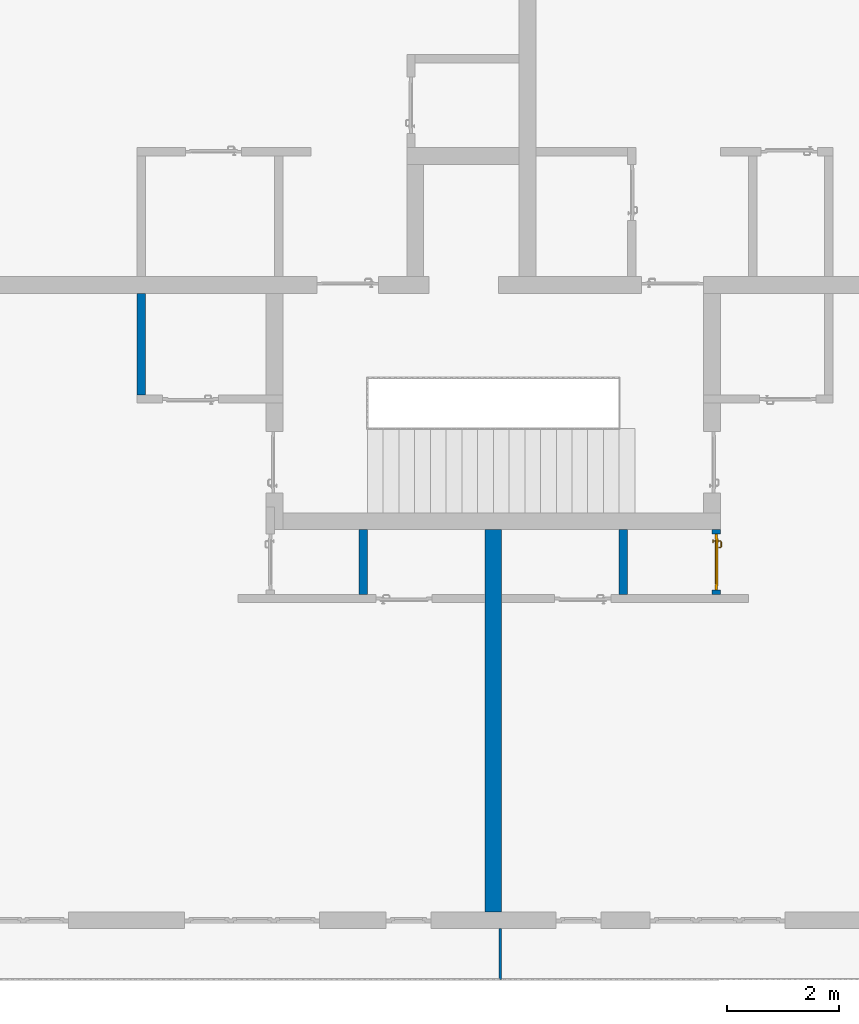
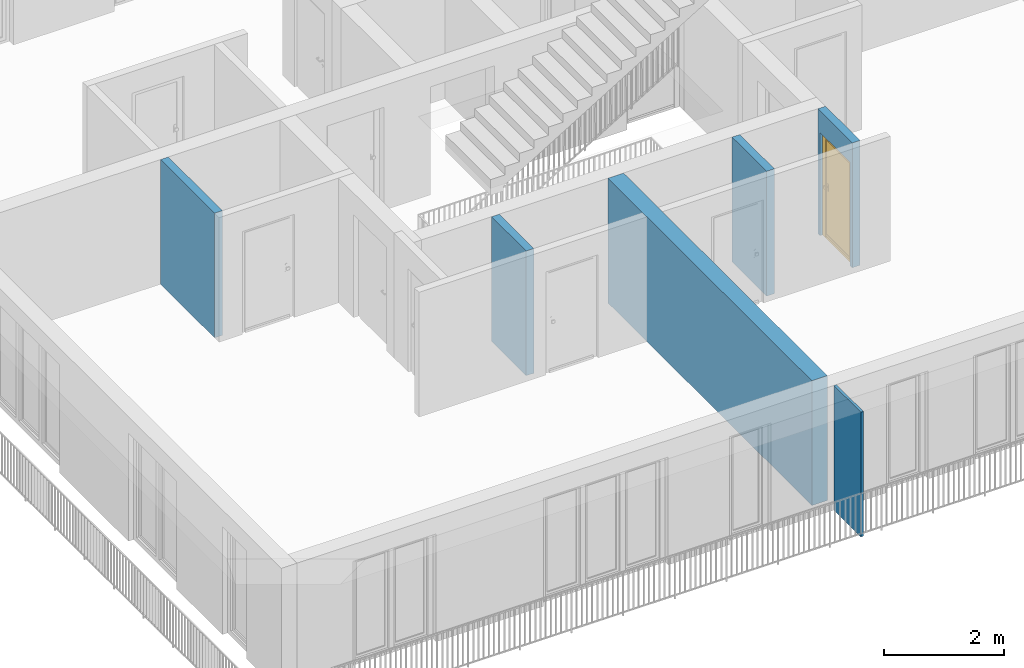
# One storey, part 4 of 48: 6 walls, 1 door, 1 opening.
"""IFC4 building model written with IfcOpenShell, lengths in metres."""

from ifc_helpers import new_model, entity, si_unit, converted_unit, derived_unit, direction, frame, origin_with_axes, place, context, subcontext, project, spatial, polygons, source, transform, mapped, material, type_object, element, fill, save


model = new_model("IFC4")

# Units and contexts
model_context = context("Model", 3, precision=1e-05, world=origin_with_axes(), true_north=direction((0.0, 1.0)))
body_context = subcontext(model_context, "Body", "Model", "MODEL_VIEW")
ifc_project = project(units=[si_unit("LENGTHUNIT", "METRE"), si_unit("AREAUNIT", "SQUARE_METRE"), si_unit("VOLUMEUNIT", "CUBIC_METRE"), converted_unit("PLANEANGLEUNIT", "DEGREE", entity("IfcPlaneAngleMeasure", 0.0174532925199), si_unit("PLANEANGLEUNIT", "RADIAN"), dimensions=[0, 0, 0, 0, 0, 0, 0]), converted_unit("TIMEUNIT", "Year", entity("IfcTimeMeasure", 31556926.0), si_unit("TIMEUNIT", "SECOND"), dimensions=[0, 0, 1, 0, 0, 0, 0]), si_unit("MASSUNIT", "GRAM", prefix="KILO"), si_unit("THERMODYNAMICTEMPERATUREUNIT", "DEGREE_CELSIUS"), si_unit("LUMINOUSINTENSITYUNIT", "LUMEN"), si_unit("ENERGYUNIT", "JOULE", prefix="MEGA"), derived_unit("THERMALCONDUCTANCEUNIT", [(si_unit("POWERUNIT", "WATT"), 1), (si_unit("LENGTHUNIT", "METRE"), -1), (si_unit("THERMODYNAMICTEMPERATUREUNIT", "KELVIN"), -1)]), derived_unit("SPECIFICHEATCAPACITYUNIT", [(si_unit("ENERGYUNIT", "JOULE"), 1), (si_unit("MASSUNIT", "GRAM", prefix="KILO"), -1), (si_unit("THERMODYNAMICTEMPERATUREUNIT", "KELVIN"), -1)]), derived_unit("MASSDENSITYUNIT", [(si_unit("MASSUNIT", "GRAM", prefix="KILO"), 1), (si_unit("VOLUMEUNIT", "CUBIC_METRE"), -1)])], contexts=[model_context])

# Site, building, storey
site_placement = place(None, origin_with_axes())
site = spatial("IfcSite", under=ifc_project, at=site_placement, CompositionType="ELEMENT")
building_placement = place(site_placement, origin_with_axes())
building = spatial("IfcBuilding", under=site, at=building_placement, CompositionType="ELEMENT")
storey_placement = place(building_placement, frame((0.0, 0.0, 3.4), z_axis=(0.0, 0.0, 1.0), x_axis=(1.0, 0.0, 0.0)))
storey = spatial("IfcBuildingStorey", under=building, at=storey_placement, Name="1. Geschoss", CompositionType="ELEMENT", Elevation=3.4)

# Wall
ifc_material_1 = material()
wall_type_1 = type_object("IfcWallType", Name="300", PredefinedType="NOTDEFINED")
wall_1_placement = place(storey_placement, frame((-1.2021993804, -2.52881223104, 0.0), z_axis=(0.0, 0.0, 1.0), x_axis=(0.0, -1.0, 0.0)))
element("IfcWall", 1, at=wall_1_placement, inside=storey, type_object=wall_type_1, material=ifc_material_1, Name="Wand-001", PredefinedType="NOTDEFINED", context=body_context, shape_type="Tessellation", body=[
    polygons([(0.3, -0.15, 0.0), (0.3, -0.15, 2.54), (0.3, 0.15, 2.54), (0.3, 0.15, 0.0), (7.1, -0.15, 0.0), (7.1, -0.15, 2.54), (7.1, 0.15, 2.54), (7.1, 0.15, 0.0)], [[[1, 2, 3, 4]], [[5, 6, 2, 1]], [[6, 7, 3, 2]], [[4, 3, 7, 8]], [[1, 4, 8, 5]], [[8, 7, 6, 5]]], closed=True),
])

# Wall, opening, door
wall_type_2 = type_object("IfcWallType", Name="150", PredefinedType="NOTDEFINED")
wall_2_placement = place(storey_placement, frame((2.8378006196, -4.12881223104, 0.0), z_axis=(0.0, 0.0, 1.0), x_axis=(0.0, 1.0, 0.0)))
wall_2 = element("IfcWall", 2, at=wall_2_placement, inside=storey, type_object=wall_type_2, material=ifc_material_1, Name="Wand-002", PredefinedType="NOTDEFINED", context=body_context, shape_type="Tessellation", body=[
    polygons([(0.225, 0.0, 0.0), (0.225, 0.0, 2.1), (1.225, 0.0, 2.1), (1.225, 0.0, 0.0), (1.3, 0.0, 0.0), (1.3, 0.0, 2.54), (0.15, 0.0, 2.54), (0.15, 0.0, 0.0), (0.225, 0.1, 0.0), (0.225, 0.15, 0.0), (0.225, 0.15, 2.1), (1.225, 0.15, 2.1), (1.225, 0.1, 0.0), (1.225, 0.15, 0.0), (1.3, 0.15, 0.0), (1.3, 0.15, 2.54), (0.15, 0.15, 2.54), (0.15, 0.15, 0.0)], [[[1, 2, 3, 4, 5, 6, 7, 8]], [[2, 1, 9, 10, 11]], [[3, 2, 11, 12]], [[13, 4, 3, 12, 14]], [[4, 13, 14, 15, 5]], [[6, 5, 15, 16]], [[6, 16, 17, 7]], [[17, 18, 8, 7]], [[9, 1, 8, 18, 10]], [[15, 14, 12, 11, 10, 18, 17, 16]]], closed=True),
])
opening_placement = place(wall_2_placement, frame((0.725, 0.0, 0.0), z_axis=(0.0, 0.0, 1.0), x_axis=(1.0, 0.0, 0.0)))
opening = element("IfcOpeningElement", 3, at=opening_placement, cuts=wall_2, context=body_context, identifier="Reference", shape_type="Tessellation", body=[
    polygons([(-0.5, 0.1, 0.0), (-0.5, 0.1, 2.1), (-0.5, 0.151, 2.1), (-0.5, 0.151, 0.0), (-0.5, -0.001, 0.0), (-0.5, -0.001, 2.1), (0.5, 0.1, 2.1), (0.5, 0.151, 2.1), (0.5, -0.001, 2.1), (0.5, 0.151, 0.0), (0.5, 0.1, 0.0), (0.5, -0.001, 0.0)], [[[1, 2, 3, 4]], [[2, 1, 5, 6]], [[7, 8, 3, 2, 6, 9]], [[8, 10, 4, 3]], [[1, 4, 10, 11, 12, 5]], [[6, 5, 12, 9]], [[7, 11, 10, 8]], [[11, 7, 9, 12]]], closed=True),
])
door_type = type_object("IfcDoorType", Name="Eingang 01 1-Fl 26", OperationType="SINGLE_SWING_RIGHT", PredefinedType="DOOR")
shared_shape = source(origin_with_axes(), body_context, "Body", "Tessellation", [
    polygons([(0.5, -0.05, 0.0), (0.5, -0.03, 0.0), (0.5, -0.03, 2.1), (0.5, -0.05, 2.1), (0.4, -0.05, 0.0), (0.4, -0.03, 0.0), (0.4, -0.03, 2.0), (0.1301, -0.03, 2.0), (0.0001, -0.03, 2.0), (-0.4, -0.03, 2.0), (-0.4, -0.03, 0.0), (-0.5, -0.03, 0.0), (-0.5, -0.03, 2.1), (-0.5, -0.05, 2.1), (-0.5, -0.05, 0.0), (-0.4, -0.05, 0.0), (-0.4, -0.05, 2.0), (0.0001, -0.05, 2.0), (0.1301, -0.05, 2.0), (0.4, -0.05, 2.0)], [[[1, 2, 3, 4]], [[5, 6, 2, 1]], [[2, 6, 7, 8, 9, 10, 11, 12, 13, 3]], [[4, 3, 13, 14]], [[1, 4, 14, 15, 16, 17, 18, 19, 20, 5]], [[20, 7, 6, 5]], [[19, 8, 7, 20]], [[18, 9, 8, 19]], [[17, 10, 9, 18]], [[16, 11, 10, 17]], [[15, 12, 11, 16]], [[14, 13, 12, 15]]], closed=True),
    polygons([(0.5, -0.03, 0.0), (0.5, 0.0, 0.0), (0.5, 0.0, 2.1), (0.5, -0.03, 2.1), (0.43, -0.03, 0.0), (0.43, 0.0, 0.0), (0.43, 0.0, 2.03), (0.1001, 0.0, 2.03), (0.0301, 0.0, 2.03), (-0.43, 0.0, 2.03), (-0.43, 0.0, 0.0), (-0.5, 0.0, 0.0), (-0.5, 0.0, 2.1), (-0.5, -0.03, 2.1), (-0.5, -0.03, 0.0), (-0.43, -0.03, 0.0), (-0.43, -0.03, 2.03), (0.0301, -0.03, 2.03), (0.1001, -0.03, 2.03), (0.43, -0.03, 2.03)], [[[1, 2, 3, 4]], [[5, 6, 2, 1]], [[2, 6, 7, 8, 9, 10, 11, 12, 13, 3]], [[4, 3, 13, 14]], [[1, 4, 14, 15, 16, 17, 18, 19, 20, 5]], [[20, 7, 6, 5]], [[19, 8, 7, 20]], [[18, 9, 8, 19]], [[17, 10, 9, 18]], [[16, 11, 10, 17]], [[15, 12, 11, 16]], [[14, 13, 12, 15]]], closed=True),
    polygons([(0.43, 0.01, 0.0), (-0.43, 0.01, 0.0), (-0.43, 0.01, 2.03), (0.43, 0.01, 2.03), (0.43, -0.03, 0.0), (-0.43, -0.03, 0.0), (-0.43, -0.03, 2.03), (0.43, -0.03, 2.03)], [[[1, 2, 3, 4]], [[2, 1, 5, 6]], [[3, 2, 6, 7]], [[4, 3, 7, 8]], [[1, 4, 8, 5]], [[6, 5, 8, 7]]], closed=True),
    polygons([(0.395, -0.05, 0.0), (0.395, -0.05, 0.05), (-0.395, -0.05, 0.05), (-0.395, -0.05, 0.0), (0.395, -0.03, 0.0), (0.395, -0.03, 0.07), (0.395, -0.035, 0.07), (-0.395, -0.035, 0.07), (-0.395, -0.03, 0.07), (-0.395, -0.03, 0.0)], [[[1, 2, 3, 4]], [[1, 5, 6, 7, 2]], [[2, 7, 8, 3]], [[4, 3, 8, 9, 10]], [[5, 1, 4, 10]], [[6, 5, 10, 9]], [[7, 6, 9, 8]]], closed=True),
    polygons([(-0.3835, 0.02, 1.0733826859), (-0.3835, 0.0199, 1.0733826859), (-0.37, 0.0199, 1.077), (-0.37, 0.02, 1.077), (-0.393382685902, 0.02, 1.0635), (-0.393382685902, 0.0199, 1.0635), (-0.3835, 0.0101, 1.0733826859), (-0.37, 0.0101, 1.077), (-0.3565, 0.0199, 1.0733826859), (-0.3565, 0.02, 1.0733826859), (-0.346617314098, 0.02, 1.0635), (-0.343, 0.02, 1.05), (-0.346617314098, 0.02, 1.0365), (-0.3565, 0.02, 1.0266173141), (-0.37, 0.02, 1.023), (-0.3835, 0.02, 1.0266173141), (-0.393382685902, 0.02, 1.0365), (-0.397, 0.02, 1.05), (-0.397, 0.0199, 1.05), (-0.393382685902, 0.0101, 1.0635), (-0.3835, 0.01, 1.0733826859), (-0.37, 0.01, 1.077), (-0.3565, 0.0101, 1.0733826859), (-0.346617314098, 0.0199, 1.0635), (-0.343, 0.0199, 1.05), (-0.346617314098, 0.0199, 1.0365), (-0.3565, 0.0199, 1.0266173141), (-0.37, 0.0199, 1.023), (-0.3835, 0.0199, 1.0266173141), (-0.393382685902, 0.0199, 1.0365), (-0.397, 0.0101, 1.05), (-0.393382685902, 0.01, 1.0635), (-0.397, 0.01, 1.05), (-0.393382685902, 0.01, 1.0365), (-0.3835, 0.01, 1.0266173141), (-0.37, 0.01, 1.023), (-0.3565, 0.01, 1.0266173141), (-0.346617314098, 0.01, 1.0365), (-0.343, 0.01, 1.05), (-0.346617314098, 0.01, 1.0635), (-0.3565, 0.01, 1.0733826859), (-0.346617314098, 0.0101, 1.0635), (-0.343, 0.0101, 1.05), (-0.346617314098, 0.0101, 1.0365), (-0.3565, 0.0101, 1.0266173141), (-0.37, 0.0101, 1.023), (-0.3835, 0.0101, 1.0266173141), (-0.393382685902, 0.0101, 1.0365)], [[[1, 2, 3, 4]], [[5, 6, 2, 1]], [[2, 7, 8, 3]], [[4, 3, 9, 10]], [[4, 10, 11, 12, 13, 14, 15, 16, 17, 18, 5, 1]], [[18, 19, 6, 5]], [[6, 20, 7, 2]], [[7, 21, 22, 8]], [[3, 8, 23, 9]], [[10, 9, 24, 11]], [[11, 24, 25, 12]], [[12, 25, 26, 13]], [[13, 26, 27, 14]], [[14, 27, 28, 15]], [[15, 28, 29, 16]], [[16, 29, 30, 17]], [[17, 30, 19, 18]], [[19, 31, 20, 6]], [[20, 32, 21, 7]], [[22, 21, 32, 33, 34, 35, 36, 37, 38, 39, 40, 41]], [[8, 22, 41, 23]], [[9, 23, 42, 24]], [[24, 42, 43, 25]], [[25, 43, 44, 26]], [[26, 44, 45, 27]], [[27, 45, 46, 28]], [[28, 46, 47, 29]], [[29, 47, 48, 30]], [[30, 48, 31, 19]], [[31, 33, 32, 20]], [[48, 34, 33, 31]], [[47, 35, 34, 48]], [[46, 36, 35, 47]], [[45, 37, 36, 46]], [[44, 38, 37, 45]], [[43, 39, 38, 44]], [[42, 40, 39, 43]], [[23, 41, 40, 42]]], closed=True),
    polygons([(-0.362532169224, 0.019, 0.959692280177), (-0.365, 0.019, 0.9544), (-0.365, 0.019, 0.952886751346), (-0.347569942042, 0.019, 0.96295), (-0.35705, 0.019, 0.972430057958), (-0.363279754556, 0.019, 0.961639806549), (-0.362532169224, 0.02, 0.959692280177), (-0.365, 0.02, 0.9544), (-0.365, 0.02, 0.952886751346), (-0.365, 0.02, 0.95), (-0.365, 0.02, 0.947113248654), (-0.365, 0.02, 0.941339745962), (-0.365, 0.02, 0.9375), (-0.365, 0.019, 0.9375), (-0.365, 0.019, 0.941339745962), (-0.365, 0.019, 0.947113248654), (-0.365, 0.019, 0.95), (-0.3441, 0.019, 0.95), (-0.347483339502, 0.019, 0.963), (-0.357, 0.019, 0.972516660498), (-0.364624817685, 0.019, 0.965143815798), (-0.37, 0.019, 0.9759), (-0.37, 0.019, 0.967425445323), (-0.364624817685, 0.02, 0.965143815798), (-0.363279754556, 0.02, 0.961639806549), (-0.35655, 0.02, 0.973296083362), (-0.346703916638, 0.02, 0.96345), (-0.3431, 0.02, 0.95), (-0.346703916638, 0.02, 0.93655), (-0.35655, 0.02, 0.926703916638), (-0.37, 0.02, 0.9231), (-0.37, 0.02, 0.9325), (-0.366464466094, 0.02, 0.933964466094), (-0.366464466094, 0.019, 0.933964466094), (-0.35705, 0.019, 0.927569942042), (-0.37, 0.019, 0.9325), (-0.37, 0.019, 0.9241), (-0.347569942042, 0.019, 0.93705), (-0.344, 0.019, 0.95), (-0.347483339502, 0.0189, 0.963), (-0.357, 0.0189, 0.972516660498), (-0.37, 0.019, 0.976), (-0.375375182315, 0.019, 0.965143815798), (-0.38295, 0.019, 0.972430057958), (-0.376720245444, 0.019, 0.961639806549), (-0.37, 0.02, 0.967425445323), (-0.37, 0.02, 0.9769), (-0.346617314098, 0.02, 0.9635), (-0.3565, 0.02, 0.973382685902), (-0.343, 0.02, 0.95), (-0.346617314098, 0.02, 0.9365), (-0.3565, 0.02, 0.926617314098), (-0.38345, 0.02, 0.926703916638), (-0.375, 0.02, 0.941339745962), (-0.375, 0.02, 0.9375), (-0.373535533906, 0.02, 0.933964466094), (-0.37, 0.02, 0.923), (-0.373535533906, 0.019, 0.933964466094), (-0.375, 0.019, 0.9375), (-0.375, 0.019, 0.941339745962), (-0.38295, 0.019, 0.927569942042), (-0.37, 0.019, 0.924), (-0.357, 0.019, 0.927483339502), (-0.347483339502, 0.019, 0.937), (-0.344, 0.0189, 0.95), (-0.347483339502, 0.0101, 0.963), (-0.357, 0.0101, 0.972516660498), (-0.37, 0.0189, 0.976), (-0.383, 0.019, 0.972516660498), (-0.375375182315, 0.02, 0.965143815798), (-0.377467830776, 0.019, 0.959692280177), (-0.392430057958, 0.019, 0.96295), (-0.375, 0.019, 0.952886751346), (-0.375, 0.019, 0.9544), (-0.377467830776, 0.02, 0.959692280177), (-0.376720245444, 0.02, 0.961639806549), (-0.38345, 0.02, 0.973296083362), (-0.37, 0.02, 0.977), (-0.346617314098, 0.0199, 0.9635), (-0.3565, 0.0199, 0.973382685902), (-0.343, 0.0199, 0.95), (-0.346617314098, 0.0199, 0.9365), (-0.3565, 0.0199, 0.926617314098), (-0.393296083362, 0.02, 0.93655), (-0.375, 0.02, 0.947113248654), (-0.375, 0.02, 0.9544), (-0.375, 0.019, 0.95), (-0.375, 0.019, 0.947113248654), (-0.375, 0.02, 0.95), (-0.375, 0.02, 0.952886751346), (-0.3835, 0.02, 0.926617314098), (-0.37, 0.0199, 0.923), (-0.392430057958, 0.019, 0.93705), (-0.383, 0.019, 0.927483339502), (-0.37, 0.0189, 0.924), (-0.357, 0.0189, 0.927483339502), (-0.347483339502, 0.0189, 0.937), (-0.344, 0.0101, 0.95), (-0.347483339502, 0.01, 0.963), (-0.357, 0.01, 0.972516660498), (-0.37, 0.0101, 0.976), (-0.383, 0.0189, 0.972516660498), (-0.392516660498, 0.019, 0.963), (-0.3959, 0.019, 0.95), (-0.393296083362, 0.02, 0.96345), (-0.3835, 0.02, 0.973382685902), (-0.37, 0.0199, 0.977), (-0.346617314098, 0.0101, 0.9635), (-0.3565, 0.0101, 0.973382685902), (-0.343, 0.0101, 0.95), (-0.346617314098, 0.0101, 0.9365), (-0.3565, 0.0101, 0.926617314098), (-0.393382685902, 0.02, 0.9365), (-0.3969, 0.02, 0.95), (-0.3835, 0.0199, 0.926617314098), (-0.37, 0.0101, 0.923), (-0.392516660498, 0.019, 0.937), (-0.383, 0.0189, 0.927483339502), (-0.37, 0.0101, 0.924), (-0.357, 0.0101, 0.927483339502), (-0.347483339502, 0.0101, 0.937), (-0.344, 0.01, 0.95), (-0.347396736961, 0.01, 0.96305), (-0.35695, 0.01, 0.972603263039), (-0.37, 0.01, 0.976), (-0.383, 0.0101, 0.972516660498), (-0.392516660498, 0.0189, 0.963), (-0.396, 0.019, 0.95), (-0.393382685902, 0.02, 0.9635), (-0.3835, 0.0199, 0.973382685902), (-0.37, 0.0101, 0.977), (-0.346617314098, 0.01, 0.9635), (-0.3565, 0.01, 0.973382685902), (-0.343, 0.01, 0.95), (-0.346617314098, 0.01, 0.9365), (-0.3565, 0.01, 0.926617314098), (-0.397, 0.02, 0.95), (-0.393382685902, 0.0199, 0.9365), (-0.3835, 0.0101, 0.926617314098), (-0.37, 0.01, 0.923), (-0.392516660498, 0.0189, 0.937), (-0.383, 0.0101, 0.927483339502), (-0.37, 0.01, 0.924), (-0.357, 0.01, 0.927483339502), (-0.347483339502, 0.01, 0.937), (-0.3439, 0.01, 0.95), (-0.346703916638, 0.01, 0.96345), (-0.35655, 0.01, 0.973296083362), (-0.37, 0.01, 0.9761), (-0.383, 0.01, 0.972516660498), (-0.392516660498, 0.0101, 0.963), (-0.396, 0.0189, 0.95), (-0.393382685902, 0.0199, 0.9635), (-0.3835, 0.0101, 0.973382685902), (-0.37, 0.01, 0.977), (-0.3431, 0.01, 0.95), (-0.346703916638, 0.01, 0.93655), (-0.35655, 0.01, 0.926703916638), (-0.397, 0.0199, 0.95), (-0.393382685902, 0.0101, 0.9365), (-0.3835, 0.01, 0.926617314098), (-0.37, 0.01, 0.9231), (-0.392516660498, 0.0101, 0.937), (-0.383, 0.01, 0.927483339502), (-0.37, 0.01, 0.9239), (-0.35695, 0.01, 0.927396736961), (-0.347396736961, 0.01, 0.93695), (-0.37, 0.01, 0.9769), (-0.38305, 0.01, 0.972603263039), (-0.392516660498, 0.01, 0.963), (-0.396, 0.0101, 0.95), (-0.393382685902, 0.0101, 0.9635), (-0.3835, 0.01, 0.973382685902), (-0.397, 0.0101, 0.95), (-0.393382685902, 0.01, 0.9365), (-0.38345, 0.01, 0.926703916638), (-0.392516660498, 0.01, 0.937), (-0.38305, 0.01, 0.927396736961), (-0.38345, 0.01, 0.973296083362), (-0.392603263039, 0.01, 0.96305), (-0.396, 0.01, 0.95), (-0.393382685902, 0.01, 0.9635), (-0.397, 0.01, 0.95), (-0.393296083362, 0.01, 0.93655), (-0.392603263039, 0.01, 0.93695), (-0.393296083362, 0.01, 0.96345), (-0.3961, 0.01, 0.95), (-0.3969, 0.01, 0.95)], [[[1, 2, 3, 4, 5, 6]], [[2, 1, 7, 8]], [[2, 8, 9, 10, 11, 12, 13, 14, 15, 16, 17, 3]], [[17, 18, 4, 3]], [[4, 19, 20, 5]], [[21, 6, 5, 22, 23]], [[1, 6, 21, 24, 25, 7]], [[7, 25, 26, 27, 9, 8]], [[9, 27, 28, 10]], [[10, 28, 29, 11]], [[11, 29, 30, 12]], [[31, 32, 33, 13, 12, 30]], [[14, 13, 33, 34]], [[35, 15, 14, 34, 36, 37]], [[15, 35, 38, 16]], [[16, 38, 18, 17]], [[18, 39, 19, 4]], [[19, 40, 41, 20]], [[5, 20, 42, 22]], [[43, 23, 22, 44, 45]], [[21, 23, 46, 24]], [[24, 46, 47, 26, 25]], [[48, 27, 26, 49]], [[50, 28, 27, 48]], [[51, 29, 28, 50]], [[52, 30, 29, 51]], [[53, 54, 55, 56, 32, 31]], [[34, 33, 32, 36]], [[57, 31, 30, 52]], [[37, 36, 58, 59, 60, 61]], [[37, 62, 63, 35]], [[35, 63, 64, 38]], [[38, 64, 39, 18]], [[39, 65, 40, 19]], [[40, 66, 67, 41]], [[20, 41, 68, 42]], [[22, 42, 69, 44]], [[23, 43, 70, 46]], [[71, 45, 44, 72, 73, 74]], [[43, 45, 71, 75, 76, 70]], [[70, 76, 77, 47, 46]], [[49, 26, 47, 78]], [[79, 48, 49, 80]], [[81, 50, 48, 79]], [[82, 51, 50, 81]], [[83, 52, 51, 82]], [[54, 53, 84, 85]], [[86, 74, 73, 87, 88, 60, 59, 55, 54, 85, 89, 90]], [[58, 56, 55, 59]], [[36, 32, 56, 58]], [[91, 53, 31, 57]], [[92, 57, 52, 83]], [[88, 93, 61, 60]], [[61, 94, 62, 37]], [[62, 95, 96, 63]], [[63, 96, 97, 64]], [[64, 97, 65, 39]], [[65, 98, 66, 40]], [[66, 99, 100, 67]], [[41, 67, 101, 68]], [[42, 68, 102, 69]], [[44, 69, 103, 72]], [[73, 72, 104, 87]], [[71, 74, 86, 75]], [[75, 86, 90, 105, 77, 76]], [[78, 47, 77, 106]], [[80, 49, 78, 107]], [[108, 79, 80, 109]], [[110, 81, 79, 108]], [[111, 82, 81, 110]], [[112, 83, 82, 111]], [[113, 84, 53, 91]], [[85, 84, 114, 89]], [[87, 104, 93, 88]], [[89, 114, 105, 90]], [[115, 91, 57, 92]], [[116, 92, 83, 112]], [[93, 117, 94, 61]], [[94, 118, 95, 62]], [[95, 119, 120, 96]], [[96, 120, 121, 97]], [[97, 121, 98, 65]], [[98, 122, 99, 66]], [[99, 123, 124, 100]], [[67, 100, 125, 101]], [[68, 101, 126, 102]], [[69, 102, 127, 103]], [[72, 103, 128, 104]], [[106, 77, 105, 129]], [[107, 78, 106, 130]], [[109, 80, 107, 131]], [[132, 108, 109, 133]], [[134, 110, 108, 132]], [[135, 111, 110, 134]], [[136, 112, 111, 135]], [[137, 114, 84, 113]], [[138, 113, 91, 115]], [[104, 128, 117, 93]], [[129, 105, 114, 137]], [[139, 115, 92, 116]], [[140, 116, 112, 136]], [[117, 141, 118, 94]], [[118, 142, 119, 95]], [[119, 143, 144, 120]], [[120, 144, 145, 121]], [[121, 145, 122, 98]], [[122, 146, 123, 99]], [[123, 147, 148, 124]], [[100, 124, 149, 125]], [[101, 125, 150, 126]], [[102, 126, 151, 127]], [[103, 127, 152, 128]], [[130, 106, 129, 153]], [[131, 107, 130, 154]], [[133, 109, 131, 155]], [[147, 132, 133, 148]], [[156, 134, 132, 147]], [[157, 135, 134, 156]], [[158, 136, 135, 157]], [[159, 137, 113, 138]], [[160, 138, 115, 139]], [[128, 152, 141, 117]], [[153, 129, 137, 159]], [[161, 139, 116, 140]], [[162, 140, 136, 158]], [[141, 163, 142, 118]], [[142, 164, 143, 119]], [[143, 165, 166, 144]], [[144, 166, 167, 145]], [[145, 167, 146, 122]], [[146, 156, 147, 123]], [[124, 148, 168, 149]], [[125, 149, 169, 150]], [[126, 150, 170, 151]], [[127, 151, 171, 152]], [[154, 130, 153, 172]], [[155, 131, 154, 173]], [[148, 133, 155, 168]], [[167, 157, 156, 146]], [[166, 158, 157, 167]], [[174, 159, 138, 160]], [[175, 160, 139, 161]], [[152, 171, 163, 141]], [[172, 153, 159, 174]], [[176, 161, 140, 162]], [[165, 162, 158, 166]], [[163, 177, 164, 142]], [[164, 178, 165, 143]], [[149, 168, 179, 169]], [[150, 169, 180, 170]], [[151, 170, 181, 171]], [[173, 154, 172, 182]], [[168, 155, 173, 179]], [[183, 174, 160, 175]], [[184, 175, 161, 176]], [[171, 181, 177, 163]], [[182, 172, 174, 183]], [[178, 176, 162, 165]], [[177, 185, 178, 164]], [[169, 179, 186, 180]], [[170, 180, 187, 181]], [[179, 173, 182, 186]], [[188, 183, 175, 184]], [[185, 184, 176, 178]], [[181, 187, 185, 177]], [[186, 182, 183, 188]], [[180, 186, 188, 187]], [[187, 188, 184, 185]]], closed=True),
    polygons([(-0.38, 0.02, 1.05), (-0.38, 0.0509849140336, 1.05), (-0.377071067812, 0.050696439392, 1.04292893219), (-0.377071067812, 0.02, 1.04292893219), (-0.377071067812, 0.02, 1.05707106781), (-0.377071067812, 0.050696439392, 1.05707106781), (-0.378277987014, 0.0596420579258, 1.05), (-0.375518993221, 0.0584992452783, 1.04292893219), (-0.37, 0.05, 1.04), (-0.37, 0.02, 1.04), (-0.37, 0.02, 1.06), (-0.37, 0.05, 1.06), (-0.375518993221, 0.0584992452783, 1.05707106781), (-0.372816199938, 0.0678161999379, 1.05), (-0.370704557509, 0.0657045575088, 1.04292893219), (-0.368858192988, 0.0557402514855, 1.04), (-0.362928932188, 0.049303560608, 1.04292893219), (-0.362928932188, 0.02, 1.04292893219), (-0.362928932188, 0.02, 1.05707106781), (-0.362928932188, 0.049303560608, 1.05707106781), (-0.368858192988, 0.0557402514855, 1.06), (-0.370704557509, 0.0657045575088, 1.05707106781), (-0.364642057926, 0.0732779870137, 1.05), (-0.363499245278, 0.0705189932208, 1.04292893219), (-0.365606601718, 0.0606066017178, 1.04), (-0.362197392755, 0.0529812576926, 1.04292893219), (-0.36, 0.0490150859664, 1.05), (-0.36, 0.02, 1.05), (-0.362197392755, 0.0529812576926, 1.05707106781), (-0.365606601718, 0.0606066017178, 1.06), (-0.363499245278, 0.0705189932208, 1.05707106781), (-0.355984914034, 0.075, 1.05), (-0.355696439392, 0.0720710678119, 1.04292893219), (-0.360740251485, 0.0638581929877, 1.04), (-0.360508645927, 0.0555086459268, 1.04292893219), (-0.359438398962, 0.0518384450452, 1.05), (-0.360508645927, 0.0555086459268, 1.05707106781), (-0.360740251485, 0.0638581929877, 1.06), (-0.355696439392, 0.0720710678119, 1.05707106781), (-0.274015085966, 0.075, 1.05), (-0.274303560608, 0.0720710678119, 1.04292893219), (-0.355, 0.065, 1.04), (-0.357981257693, 0.0571973927545, 1.04292893219), (-0.358397003498, 0.0533970034977, 1.05), (-0.357981257693, 0.0571973927545, 1.05707106781), (-0.355, 0.065, 1.06), (-0.274303560608, 0.0720710678119, 1.05707106781), (-0.265357942074, 0.0732779870137, 1.05), (-0.266500754722, 0.0705189932208, 1.04292893219), (-0.275, 0.065, 1.04), (-0.354303560608, 0.0579289321881, 1.04292893219), (-0.356838445045, 0.0544383989617, 1.05), (-0.354303560608, 0.0579289321881, 1.05707106781), (-0.275, 0.065, 1.06), (-0.266500754722, 0.0705189932208, 1.05707106781), (-0.257183800062, 0.0678161999379, 1.05), (-0.259295442491, 0.0657045575088, 1.04292893219), (-0.269259748515, 0.0638581929877, 1.04), (-0.275696439392, 0.0579289321881, 1.04292893219), (-0.354015085966, 0.055, 1.05), (-0.275696439392, 0.0579289321881, 1.05707106781), (-0.269259748515, 0.0638581929877, 1.06), (-0.259295442491, 0.0657045575088, 1.05707106781), (-0.251722012986, 0.0596420579258, 1.05), (-0.254481006779, 0.0584992452783, 1.04292893219), (-0.264393398282, 0.0606066017178, 1.04), (-0.272018742307, 0.0571973927545, 1.04292893219), (-0.275984914034, 0.055, 1.05), (-0.272018742307, 0.0571973927545, 1.05707106781), (-0.264393398282, 0.0606066017178, 1.06), (-0.254481006779, 0.0584992452783, 1.05707106781), (-0.25, 0.0509849140336, 1.05), (-0.252928932188, 0.050696439392, 1.04292893219), (-0.261141807012, 0.0557402514855, 1.04), (-0.269491354073, 0.0555086459268, 1.04292893219), (-0.273161554955, 0.0544383989617, 1.05), (-0.269491354073, 0.0555086459268, 1.05707106781), (-0.261141807012, 0.0557402514855, 1.06), (-0.252928932188, 0.050696439392, 1.05707106781), (-0.25, 0.02, 1.05), (-0.252928932188, 0.02, 1.04292893219), (-0.26, 0.05, 1.04), (-0.267802607245, 0.0529812576926, 1.04292893219), (-0.271602996502, 0.0533970034977, 1.05), (-0.267802607245, 0.0529812576926, 1.05707106781), (-0.26, 0.05, 1.06), (-0.252928932188, 0.02, 1.05707106781), (-0.26, 0.02, 1.06), (-0.267071067812, 0.02, 1.05707106781), (-0.27, 0.02, 1.05), (-0.267071067812, 0.02, 1.04292893219), (-0.26, 0.02, 1.04), (-0.267071067812, 0.049303560608, 1.04292893219), (-0.270561601038, 0.0518384450452, 1.05), (-0.267071067812, 0.049303560608, 1.05707106781), (-0.27, 0.0490150859664, 1.05)], [[[1, 2, 3, 4]], [[5, 6, 2, 1]], [[2, 7, 8, 3]], [[4, 3, 9, 10]], [[11, 12, 6, 5]], [[6, 13, 7, 2]], [[7, 14, 15, 8]], [[3, 8, 16, 9]], [[10, 9, 17, 18]], [[19, 20, 12, 11]], [[12, 21, 13, 6]], [[13, 22, 14, 7]], [[14, 23, 24, 15]], [[8, 15, 25, 16]], [[9, 16, 26, 17]], [[18, 17, 27, 28]], [[28, 27, 20, 19]], [[20, 29, 21, 12]], [[21, 30, 22, 13]], [[22, 31, 23, 14]], [[23, 32, 33, 24]], [[15, 24, 34, 25]], [[16, 25, 35, 26]], [[17, 26, 36, 27]], [[27, 36, 29, 20]], [[29, 37, 30, 21]], [[30, 38, 31, 22]], [[31, 39, 32, 23]], [[32, 40, 41, 33]], [[24, 33, 42, 34]], [[25, 34, 43, 35]], [[26, 35, 44, 36]], [[36, 44, 37, 29]], [[37, 45, 38, 30]], [[38, 46, 39, 31]], [[39, 47, 40, 32]], [[40, 48, 49, 41]], [[33, 41, 50, 42]], [[34, 42, 51, 43]], [[35, 43, 52, 44]], [[44, 52, 45, 37]], [[45, 53, 46, 38]], [[46, 54, 47, 39]], [[47, 55, 48, 40]], [[48, 56, 57, 49]], [[41, 49, 58, 50]], [[42, 50, 59, 51]], [[43, 51, 60, 52]], [[52, 60, 53, 45]], [[53, 61, 54, 46]], [[54, 62, 55, 47]], [[55, 63, 56, 48]], [[56, 64, 65, 57]], [[49, 57, 66, 58]], [[50, 58, 67, 59]], [[51, 59, 68, 60]], [[60, 68, 61, 53]], [[61, 69, 62, 54]], [[62, 70, 63, 55]], [[63, 71, 64, 56]], [[64, 72, 73, 65]], [[57, 65, 74, 66]], [[58, 66, 75, 67]], [[59, 67, 76, 68]], [[68, 76, 69, 61]], [[69, 77, 70, 62]], [[70, 78, 71, 63]], [[71, 79, 72, 64]], [[72, 80, 81, 73]], [[65, 73, 82, 74]], [[66, 74, 83, 75]], [[67, 75, 84, 76]], [[76, 84, 77, 69]], [[77, 85, 78, 70]], [[78, 86, 79, 71]], [[79, 87, 80, 72]], [[80, 87, 88, 89, 90, 91, 92, 81]], [[73, 81, 92, 82]], [[74, 82, 93, 83]], [[75, 83, 94, 84]], [[84, 94, 85, 77]], [[85, 95, 86, 78]], [[86, 88, 87, 79]], [[95, 89, 88, 86]], [[96, 90, 89, 95]], [[93, 91, 90, 96]], [[82, 92, 91, 93]], [[83, 93, 96, 94]], [[94, 96, 95, 85]]], closed=False),
    polygons([(-0.364696699141, -0.035, 1.04469669914), (-0.37, -0.035, 1.0425), (-0.375303300859, -0.035, 1.04469669914), (-0.3775, -0.035, 1.05), (-0.375303300859, -0.035, 1.05530330086), (-0.37, -0.035, 1.0575), (-0.364696699141, -0.035, 1.05530330086), (-0.3625, -0.035, 1.05), (-0.364696699141, -0.075, 1.04469669914), (-0.37, -0.075, 1.0425), (-0.375303300859, -0.075, 1.04469669914), (-0.3775, -0.075, 1.05), (-0.375303300859, -0.075, 1.05530330086), (-0.37, -0.075, 1.0575), (-0.364696699141, -0.075, 1.05530330086), (-0.3625, -0.075, 1.05)], [[[1, 2, 3, 4, 5, 6, 7, 8]], [[2, 1, 9, 10]], [[3, 2, 10, 11]], [[4, 3, 11, 12]], [[5, 4, 12, 13]], [[6, 5, 13, 14]], [[7, 6, 14, 15]], [[8, 7, 15, 16]], [[1, 8, 16, 9]], [[9, 16, 15, 14, 13, 12, 11, 10]]], closed=True),
    polygons([(-0.395, -0.03, 0.975), (-0.393096988313, -0.03, 0.965432914191), (-0.393096988313, -0.035, 0.965432914191), (-0.395, -0.035, 0.975), (-0.395, -0.03, 1.1), (-0.393096988313, -0.03, 1.10956708581), (-0.38767766953, -0.03, 1.11767766953), (-0.379567085809, -0.03, 1.12309698831), (-0.37, -0.03, 1.125), (-0.360432914191, -0.03, 1.12309698831), (-0.35232233047, -0.03, 1.11767766953), (-0.346903011687, -0.03, 1.10956708581), (-0.345, -0.03, 1.1), (-0.345, -0.03, 0.975), (-0.346903011687, -0.03, 0.965432914191), (-0.35232233047, -0.03, 0.95732233047), (-0.360432914191, -0.03, 0.951903011687), (-0.37, -0.03, 0.95), (-0.379567085809, -0.03, 0.951903011687), (-0.38767766953, -0.03, 0.95732233047), (-0.38767766953, -0.035, 0.95732233047), (-0.379567085809, -0.035, 0.951903011687), (-0.37, -0.035, 0.95), (-0.360432914191, -0.035, 0.951903011687), (-0.35232233047, -0.035, 0.95732233047), (-0.346903011687, -0.035, 0.965432914191), (-0.345, -0.035, 0.975), (-0.345, -0.035, 1.1), (-0.346903011687, -0.035, 1.10956708581), (-0.35232233047, -0.035, 1.11767766953), (-0.360432914191, -0.035, 1.12309698831), (-0.37, -0.035, 1.125), (-0.379567085809, -0.035, 1.12309698831), (-0.38767766953, -0.035, 1.11767766953), (-0.393096988313, -0.035, 1.10956708581), (-0.395, -0.035, 1.1)], [[[1, 2, 3, 4]], [[1, 5, 6, 7, 8, 9, 10, 11, 12, 13, 14, 15, 16, 17, 18, 19, 20, 2]], [[2, 20, 21, 3]], [[4, 3, 21, 22, 23, 24, 25, 26, 27, 28, 29, 30, 31, 32, 33, 34, 35, 36]], [[5, 1, 4, 36]], [[6, 5, 36, 35]], [[7, 6, 35, 34]], [[8, 7, 34, 33]], [[9, 8, 33, 32]], [[10, 9, 32, 31]], [[11, 10, 31, 30]], [[12, 11, 30, 29]], [[13, 12, 29, 28]], [[14, 13, 28, 27]], [[15, 14, 27, 26]], [[16, 15, 26, 25]], [[17, 16, 25, 24]], [[18, 17, 24, 23]], [[19, 18, 23, 22]], [[20, 19, 22, 21]]], closed=True),
    polygons([(-0.39, -0.075, 1.08), (-0.395, -0.075, 1.07866025404), (-0.395, -0.09, 1.07866025404), (-0.39, -0.09, 1.08), (-0.35, -0.075, 1.08), (-0.345, -0.075, 1.07866025404), (-0.341339745962, -0.075, 1.075), (-0.34, -0.075, 1.07), (-0.34, -0.075, 1.03), (-0.341339745962, -0.075, 1.025), (-0.345, -0.075, 1.02133974596), (-0.35, -0.075, 1.02), (-0.39, -0.075, 1.02), (-0.395, -0.075, 1.02133974596), (-0.398660254038, -0.075, 1.025), (-0.4, -0.075, 1.03), (-0.4, -0.075, 1.07), (-0.398660254038, -0.075, 1.075), (-0.398660254038, -0.09, 1.075), (-0.4, -0.09, 1.07), (-0.4, -0.09, 1.03), (-0.398660254038, -0.09, 1.025), (-0.395, -0.09, 1.02133974596), (-0.39, -0.09, 1.02), (-0.35, -0.09, 1.02), (-0.345, -0.09, 1.02133974596), (-0.341339745962, -0.09, 1.025), (-0.34, -0.09, 1.03), (-0.34, -0.09, 1.07), (-0.341339745962, -0.09, 1.075), (-0.345, -0.09, 1.07866025404), (-0.35, -0.09, 1.08)], [[[1, 2, 3, 4]], [[1, 5, 6, 7, 8, 9, 10, 11, 12, 13, 14, 15, 16, 17, 18, 2]], [[2, 18, 19, 3]], [[4, 3, 19, 20, 21, 22, 23, 24, 25, 26, 27, 28, 29, 30, 31, 32]], [[5, 1, 4, 32]], [[6, 5, 32, 31]], [[7, 6, 31, 30]], [[8, 7, 30, 29]], [[9, 8, 29, 28]], [[10, 9, 28, 27]], [[11, 10, 27, 26]], [[12, 11, 26, 25]], [[13, 12, 25, 24]], [[14, 13, 24, 23]], [[15, 14, 23, 22]], [[16, 15, 22, 21]], [[17, 16, 21, 20]], [[18, 17, 20, 19]]], closed=True),
])
door_placement = place(opening_placement, frame((0.4, 0.0, 0.0), z_axis=(0.0, 0.0, 1.0), x_axis=(-1.0, 0.0, 0.0)))
door = element("IfcDoor", 4, at=door_placement, inside=storey, type_object=door_type, OverallHeight=2.1, OverallWidth=1.0, PredefinedType="DOOR", context=body_context, shape_type="MappedRepresentation", body=[
    mapped(shared_shape, transform((0.4, -0.05, 0.0))),
])
fill(opening, door)

# Walls
wall_3_placement = place(storey_placement, frame((-3.5921993804, -4.12881223104, 0.0), z_axis=(0.0, 0.0, 1.0), x_axis=(0.0, 1.0, 0.0)))
element("IfcWall", 5, at=wall_3_placement, inside=storey, type_object=wall_type_2, material=ifc_material_1, Name="Wand-002", PredefinedType="NOTDEFINED", context=body_context, shape_type="Tessellation", body=[
    polygons([(1.3, 0.0, 0.0), (1.3, 0.0, 2.54), (1.3, -0.15, 2.54), (1.3, -0.15, 0.0), (0.15, 0.0, 0.0), (0.15, 0.0, 2.54), (0.15, -0.15, 2.54), (0.15, -0.15, 0.0)], [[[1, 2, 3, 4]], [[5, 6, 2, 1]], [[6, 7, 3, 2]], [[4, 3, 7, 8]], [[5, 1, 4, 8]], [[8, 7, 6, 5]]], closed=True),
])
wall_4_placement = place(storey_placement, frame((1.1878006196, -4.12881223104, 0.0), z_axis=(0.0, 0.0, 1.0), x_axis=(0.0, 1.0, 0.0)))
element("IfcWall", 6, at=wall_4_placement, inside=storey, type_object=wall_type_2, material=ifc_material_1, Name="Wand-002", PredefinedType="NOTDEFINED", context=body_context, shape_type="Tessellation", body=[
    polygons([(1.3, 0.15, 0.0), (1.3, 0.15, 2.54), (1.3, 0.0, 2.54), (1.3, 0.0, 0.0), (0.15, 0.15, 0.0), (0.15, 0.15, 2.54), (0.15, 0.0, 2.54), (0.15, 0.0, 0.0)], [[[1, 2, 3, 4]], [[5, 6, 2, 1]], [[6, 7, 3, 2]], [[4, 3, 7, 8]], [[5, 1, 4, 8]], [[8, 7, 6, 5]]], closed=True),
])
wall_5_placement = place(storey_placement, frame((-7.5421993804, 1.37118776896, 0.0), z_axis=(0.0, 0.0, 1.0), x_axis=(0.0, -1.0, 0.0)))
element("IfcWall", 7, at=wall_5_placement, inside=storey, type_object=wall_type_2, material=ifc_material_1, Name="Wand-003", PredefinedType="NOTDEFINED", context=body_context, shape_type="Tessellation", body=[
    polygons([(0.0, 0.0, 0.0), (0.0, 0.0, 2.54), (0.0, 0.15, 2.54), (0.0, 0.15, 0.0), (1.8, 0.0, 0.0), (1.8, 0.0, 2.54), (1.8, 0.15, 2.54), (1.8, 0.15, 0.0)], [[[1, 2, 3, 4]], [[5, 6, 2, 1]], [[6, 7, 3, 2]], [[4, 3, 7, 8]], [[4, 8, 5, 1]], [[8, 7, 6, 5]]], closed=True),
])
ifc_material_2 = material()
wall_type_3 = type_object("IfcWallType", Name="50", PredefinedType="NOTDEFINED")
wall_6_placement = place(storey_placement, frame((-1.0521993804, -9.62881223104, 0.0), z_axis=(0.0, 0.0, 1.0), x_axis=(0.0, -1.0, 0.0)))
element("IfcWall", 8, at=wall_6_placement, inside=storey, type_object=wall_type_3, material=ifc_material_2, Name="Wand-003", PredefinedType="NOTDEFINED", context=body_context, shape_type="Tessellation", body=[
    polygons([(0.3, -0.05, 2.54), (0.3, 0.0, 2.54), (0.3, 0.0, 0.0), (0.3, -0.05, 0.0), (1.2, 0.0, 2.54), (1.2, -0.05, 2.54), (1.2, 0.0, 0.0), (1.2, -0.05, 0.0)], [[[1, 2, 3, 4]], [[5, 2, 1, 6]], [[2, 5, 7, 3]], [[3, 7, 8, 4]], [[6, 1, 4, 8]], [[5, 6, 8, 7]]], closed=True),
])

save(model, "model.ifc")
